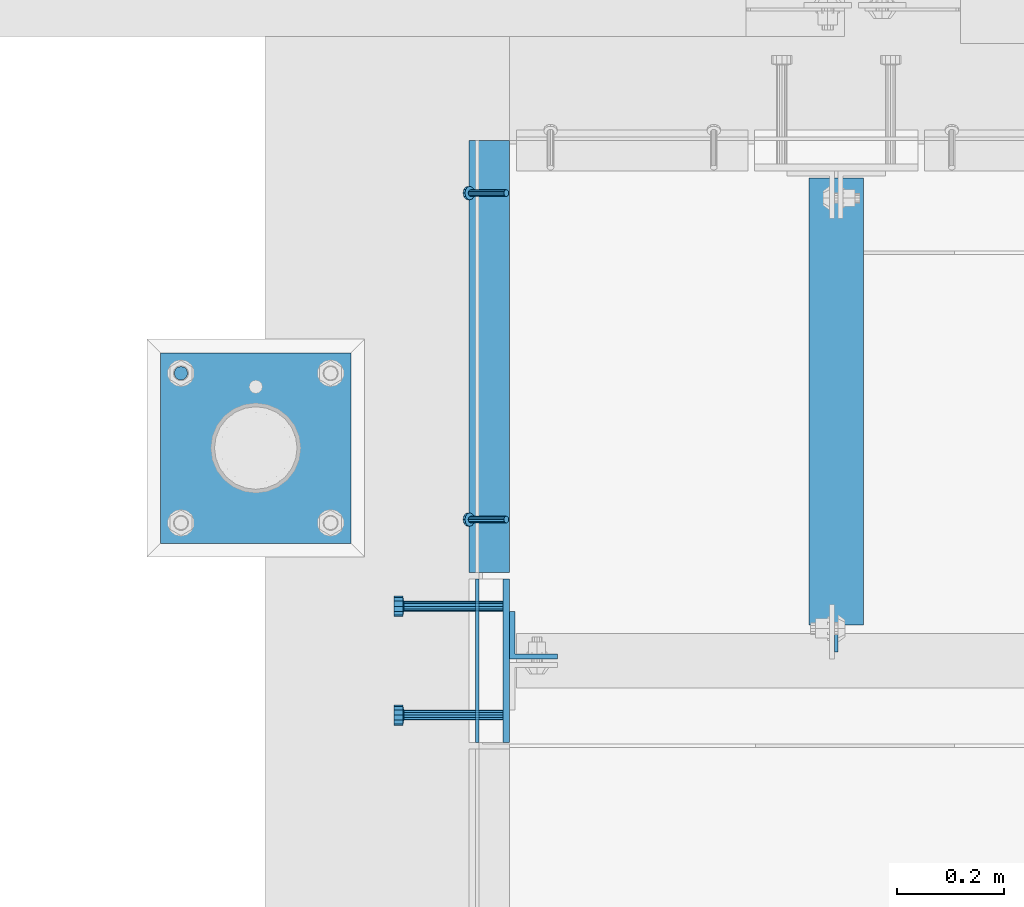
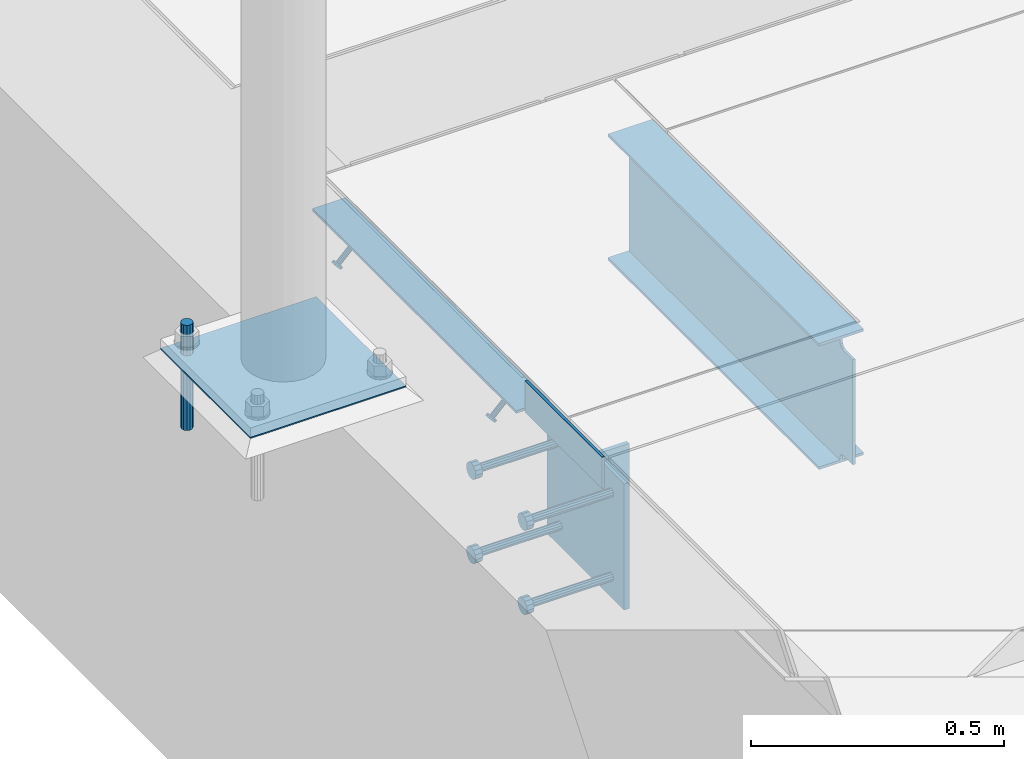
# One storey, part 2006 of 3843: 11 beams, 2 members, 5 elements without a shape of their own.
"""IFC2X3 building model written with IfcOpenShell, lengths in millimetres."""

from ifc_helpers import new_model, si_unit, frame, origin_with_axes, place, context, subcontext, project, spatial, faceted_brep, material, type_object, element, aggregate, save


model = new_model("IFC2X3")

# Units and contexts
model_context = context("Model", 3, precision=1e-05, world=origin_with_axes())
body_context = subcontext(model_context, "Body", "Model", "MODEL_VIEW")
ifc_project = project(units=[si_unit("LENGTHUNIT", "METRE", prefix="MILLI"), si_unit("AREAUNIT", "SQUARE_METRE"), si_unit("VOLUMEUNIT", "CUBIC_METRE"), si_unit("MASSUNIT", "GRAM", prefix="KILO"), si_unit("TIMEUNIT", "SECOND"), si_unit("PLANEANGLEUNIT", "RADIAN"), si_unit("SOLIDANGLEUNIT", "STERADIAN"), si_unit("THERMODYNAMICTEMPERATUREUNIT", "DEGREE_CELSIUS"), si_unit("LUMINOUSINTENSITYUNIT", "LUMEN")], contexts=[model_context])

# Site, building, storey
site_placement = place(None, origin_with_axes())
site = spatial("IfcSite", under=ifc_project, at=site_placement, CompositionType="ELEMENT")
building_placement = place(site_placement, origin_with_axes())
building = spatial("IfcBuilding", under=site, at=building_placement, Name="Undefined", CompositionType="ELEMENT")
storey_placement = place(building_placement, origin_with_axes())
storey = spatial("IfcBuildingStorey", under=building, at=storey_placement, Name="Undefined", CompositionType="ELEMENT", Elevation=0.0)

# Assembly, members
assembly_1_placement = place(storey_placement, origin_with_axes())
assembly_1 = element("IfcElementAssembly", 1, at=assembly_1_placement, inside=storey, Name="ANGLE", AssemblyPlace="NOTDEFINED", PredefinedType="RIGID_FRAME")
ifc_material_1 = material(Name="STEEL/A108")
member_type = type_object("IfcMemberType", PredefinedType="NOTDEFINED")
member_1_placement = place(assembly_1_placement, frame((41411.525, 19354.7999755859, 30397.4500030518), z_axis=(0.0, -1.0, 0.0), x_axis=(-0.707106781186548, 0.0, -0.707106781186548)))
member_1 = element("IfcMember", 2, at=member_1_placement, type_object=member_type, material=ifc_material_1, Name="HEADED STUD ANCHOR", context=body_context, shape_type="Brep", body=[
    faceted_brep([(7.27595761418343e-12, -3.18000006675175, 5.5), (0.0, -5.49999999998363, 3.1800000667572), (94.4879985803855, -5.50000000011278, 3.1800000667572), (94.4879985803782, -3.18000006687362, 5.5), (0.0, -6.3499999046162, 0.0), (94.4879985803855, -6.34999990474535, 0.0), (0.0, -5.49999999998363, -3.1800000667572), (94.4879985803855, -5.50000000011278, -3.1800000667572), (7.27595761418343e-12, -3.18000006675175, -5.5), (94.4879985803782, -3.18000006687362, -5.5), (7.27595761418343e-12, -1.81898940354586e-12, -6.34999990463257), (94.4879985803782, -1.20053300634027e-10, -6.34999990463257), (0.0, 3.18000006675175, -5.5), (94.4879985803709, 3.18000006663351, -5.5), (7.27595761418343e-12, 5.49999999998363, -3.1800000667572), (94.4879985803709, 5.49999999987267, -3.1800000667572), (7.27595761418343e-12, 6.3499999046162, 0.0), (94.4879985803673, 6.34999990450706, 0.0), (7.27595761418343e-12, 5.49999999998363, 3.1800000667572), (94.4879985803709, 5.49999999987267, 3.1800000667572), (0.0, 3.18000006675175, 5.5), (94.4879985803709, 3.18000006663351, 5.5), (7.27595761418343e-12, -1.81898940354586e-12, 6.34999990463257), (94.4879985803782, -1.20053300634027e-10, 6.34999990463257), (96.5199985498621, -10.9899997712273, 6.34999990463257), (96.5199985498548, -6.34000015270249, 10.9899997711182), (96.5199985498621, -12.6999998093743, 0.0), (96.5199985498621, -10.9899997712273, -6.34999990463257), (96.5199985498548, -6.34000015270249, -10.9899997711182), (96.5199985498475, -1.21872290037572e-10, -12.6899995803833), (96.5199985498402, 6.34000015245874, -10.9899997711182), (96.519998549833, 10.9899997709817, -6.34999990463257), (96.519998549833, 12.6999998091305, 0.0), (96.519998549833, 10.9899997709817, 6.34999990463257), (96.5199985498402, 6.34000015245874, 10.9899997711182), (96.5199985498475, -1.21872290037572e-10, 12.6899995803833), (101.599998473539, -10.9899997712328, 6.34999990463257), (101.599998473532, -6.34000015270976, 10.9899997711182), (101.599998473539, -12.6999998093797, 0.0), (101.599998473539, -10.9899997712328, -6.34999990463257), (101.599998473532, -6.34000015270976, -10.9899997711182), (101.599998473524, -1.29148247651756e-10, -12.6899995803833), (101.599998473517, 6.34000015245329, -10.9899997711182), (101.59999847351, 10.9899997709763, -6.34999990463257), (101.599998473503, 12.6999998091196, 0.0), (101.59999847351, 10.9899997709763, 6.34999990463257), (101.599998473517, 6.34000015245329, 10.9899997711182), (101.599998473524, -1.29148247651756e-10, 12.6899995803833)], [[[0, 1, 2, 3]], [[1, 4, 5, 2]], [[4, 6, 7, 5]], [[6, 8, 9, 7]], [[8, 10, 11, 9]], [[10, 12, 13, 11]], [[12, 14, 15, 13]], [[14, 16, 17, 15]], [[16, 18, 19, 17]], [[18, 20, 21, 19]], [[20, 22, 23, 21]], [[22, 0, 3, 23]], [[22, 20, 18, 16, 14, 12, 10, 8, 6, 4, 1, 0]], [[3, 2, 24, 25]], [[2, 5, 26, 24]], [[5, 7, 27, 26]], [[7, 9, 28, 27]], [[9, 11, 29, 28]], [[11, 13, 30, 29]], [[13, 15, 31, 30]], [[15, 17, 32, 31]], [[17, 19, 33, 32]], [[19, 21, 34, 33]], [[21, 23, 35, 34]], [[23, 3, 25, 35]], [[25, 24, 36, 37]], [[24, 26, 38, 36]], [[26, 27, 39, 38]], [[27, 28, 40, 39]], [[28, 29, 41, 40]], [[29, 30, 42, 41]], [[30, 31, 43, 42]], [[31, 32, 44, 43]], [[32, 33, 45, 44]], [[33, 34, 46, 45]], [[34, 35, 47, 46]], [[35, 25, 37, 47]], [[38, 39, 40, 41, 42, 43, 44, 45, 46, 47, 37, 36]]]),
])
member_2_placement = place(assembly_1_placement, frame((41411.525, 19964.3999755859, 30397.4500030518), z_axis=(0.0, -1.0, 0.0), x_axis=(-0.707106781186548, 0.0, -0.707106781186548)))
member_2 = element("IfcMember", 3, at=member_2_placement, type_object=member_type, material=ifc_material_1, Name="HEADED STUD ANCHOR", context=body_context, shape_type="Brep", body=[
    faceted_brep([(7.27595761418343e-12, -3.18000006675175, 5.5), (0.0, -5.49999999998363, 3.1800000667572), (94.4879985803855, -5.50000000011278, 3.1800000667572), (94.4879985803782, -3.18000006687362, 5.5), (0.0, -6.3499999046162, 0.0), (94.4879985803855, -6.34999990474535, 0.0), (0.0, -5.49999999998363, -3.1800000667572), (94.4879985803855, -5.50000000011278, -3.1800000667572), (7.27595761418343e-12, -3.18000006675175, -5.5), (94.4879985803782, -3.18000006687362, -5.5), (7.27595761418343e-12, -1.81898940354586e-12, -6.34999990463257), (94.4879985803782, -1.20053300634027e-10, -6.34999990463257), (0.0, 3.18000006675175, -5.5), (94.4879985803709, 3.18000006663351, -5.5), (7.27595761418343e-12, 5.49999999998363, -3.1800000667572), (94.4879985803709, 5.49999999987267, -3.1800000667572), (7.27595761418343e-12, 6.3499999046162, 0.0), (94.4879985803673, 6.34999990450706, 0.0), (7.27595761418343e-12, 5.49999999998363, 3.1800000667572), (94.4879985803709, 5.49999999987267, 3.1800000667572), (0.0, 3.18000006675175, 5.5), (94.4879985803709, 3.18000006663351, 5.5), (7.27595761418343e-12, -1.81898940354586e-12, 6.34999990463257), (94.4879985803782, -1.20053300634027e-10, 6.34999990463257), (96.5199985498621, -10.9899997712273, 6.34999990463257), (96.5199985498548, -6.34000015270249, 10.9899997711182), (96.5199985498621, -12.6999998093743, 0.0), (96.5199985498621, -10.9899997712273, -6.34999990463257), (96.5199985498548, -6.34000015270249, -10.9899997711182), (96.5199985498475, -1.21872290037572e-10, -12.6899995803833), (96.5199985498402, 6.34000015245874, -10.9899997711182), (96.519998549833, 10.9899997709817, -6.34999990463257), (96.519998549833, 12.6999998091305, 0.0), (96.519998549833, 10.9899997709817, 6.34999990463257), (96.5199985498402, 6.34000015245874, 10.9899997711182), (96.5199985498475, -1.21872290037572e-10, 12.6899995803833), (101.599998473539, -10.9899997712328, 6.34999990463257), (101.599998473532, -6.34000015270976, 10.9899997711182), (101.599998473539, -12.6999998093797, 0.0), (101.599998473539, -10.9899997712328, -6.34999990463257), (101.599998473532, -6.34000015270976, -10.9899997711182), (101.599998473524, -1.29148247651756e-10, -12.6899995803833), (101.599998473517, 6.34000015245329, -10.9899997711182), (101.59999847351, 10.9899997709763, -6.34999990463257), (101.599998473503, 12.6999998091196, 0.0), (101.59999847351, 10.9899997709763, 6.34999990463257), (101.599998473517, 6.34000015245329, 10.9899997711182), (101.599998473524, -1.29148247651756e-10, 12.6899995803833)], [[[0, 1, 2, 3]], [[1, 4, 5, 2]], [[4, 6, 7, 5]], [[6, 8, 9, 7]], [[8, 10, 11, 9]], [[10, 12, 13, 11]], [[12, 14, 15, 13]], [[14, 16, 17, 15]], [[16, 18, 19, 17]], [[18, 20, 21, 19]], [[20, 22, 23, 21]], [[22, 0, 3, 23]], [[22, 20, 18, 16, 14, 12, 10, 8, 6, 4, 1, 0]], [[3, 2, 24, 25]], [[2, 5, 26, 24]], [[5, 7, 27, 26]], [[7, 9, 28, 27]], [[9, 11, 29, 28]], [[11, 13, 30, 29]], [[13, 15, 31, 30]], [[15, 17, 32, 31]], [[17, 19, 33, 32]], [[19, 21, 34, 33]], [[21, 23, 35, 34]], [[23, 3, 25, 35]], [[25, 24, 36, 37]], [[24, 26, 38, 36]], [[26, 27, 39, 38]], [[27, 28, 40, 39]], [[28, 29, 41, 40]], [[29, 30, 42, 41]], [[30, 31, 43, 42]], [[31, 32, 44, 43]], [[32, 33, 45, 44]], [[33, 34, 46, 45]], [[34, 35, 47, 46]], [[35, 25, 37, 47]], [[38, 39, 40, 41, 42, 43, 44, 45, 46, 47, 37, 36]]]),
])

# Assembly, beams
assembly_2_placement = place(storey_placement, origin_with_axes())
assembly_2 = element("IfcElementAssembly", 4, at=assembly_2_placement, inside=storey, Name="TEMPLATE", AssemblyPlace="NOTDEFINED", PredefinedType="RIGID_FRAME")
ifc_material_2 = material(Name="STEEL/316 SS")
beam_type_1 = type_object("IfcBeamType", PredefinedType="NOTDEFINED")
beam_1_placement = place(assembly_2_placement, frame((40803.978314209, 19628.0527605797, 30581.6), z_axis=(-1.0, 0.0, 0.0), x_axis=(0.0, 0.0, -1.0)))
beam_1 = element("IfcBeam", 5, at=beam_1_placement, type_object=beam_type_1, material=ifc_material_2, Name="ANCHOR_ROD", context=body_context, shape_type="Brep", body=[
    faceted_brep([(0.0, -12.6999999999971, 0.0), (0.0, -10.9985226280696, -6.34999999999854), (253.999, -10.9985226280696, -6.34999999999854), (253.999, -12.6999999999971, 0.0), (0.0, -6.35000000000582, -10.9985226280623), (253.999, -6.35000000000582, -10.9985226280623), (0.0, 0.0, -12.6999999999971), (253.999, 0.0, -12.6999999999971), (0.0, 6.35000000000582, -10.9985226280623), (253.999, 6.35000000000582, -10.9985226280623), (0.0, 10.9985226280696, -6.34999999999854), (253.999, 10.9985226280696, -6.34999999999854), (0.0, 12.6999999999971, 0.0), (253.999, 12.6999999999971, 0.0), (0.0, 10.9985226280696, 6.34999999999854), (253.999, 10.9985226280696, 6.34999999999854), (0.0, 6.35000000000582, 10.9985226280623), (253.999, 6.35000000000582, 10.9985226280623), (0.0, 0.0, 12.6999999999971), (253.999, 0.0, 12.6999999999971), (0.0, -6.35000000000582, 10.9985226280623), (253.999, -6.35000000000582, 10.9985226280623), (0.0, -10.9985226280696, 6.34999999999854), (253.999, -10.9985226280696, 6.34999999999854)], [[[0, 1, 2, 3]], [[1, 4, 5, 2]], [[4, 6, 7, 5]], [[6, 8, 9, 7]], [[8, 10, 11, 9]], [[10, 12, 13, 11]], [[12, 14, 15, 13]], [[14, 16, 17, 15]], [[16, 18, 19, 17]], [[18, 20, 21, 19]], [[20, 22, 23, 21]], [[22, 0, 3, 23]], [[5, 7, 9, 11, 13, 15, 17, 19, 21, 23, 3, 2]], [[22, 20, 18, 16, 14, 12, 10, 8, 6, 4, 1, 0]]]),
])
ifc_material_3 = material(Name="STEEL/A36")
beam_type_2 = type_object("IfcBeamType", PredefinedType="NOTDEFINED")
beam_2_placement = place(assembly_2_placement, frame((41121.478314209, 19488.3527605797, 30506.9875), z_axis=(0.0, -1.0, 0.0), x_axis=(-1.0, 0.0, 0.0)))
beam_2 = element("IfcBeam", 6, at=beam_2_placement, type_object=beam_type_2, material=ifc_material_3, Name="TEMPLATE", context=body_context, shape_type="Brep", body=[
    faceted_brep([(0.0, 1.58750000000146, -177.800000000003), (0.0, 1.58750000000146, 177.800000000003), (355.600000000006, 1.58750000000146, 177.800000000003), (355.600000000006, 1.58750000000146, -177.800000000003), (0.0, -1.58750000000146, 177.800000000003), (355.600000000006, -1.58750000000146, 177.800000000003), (0.0, -1.58750000000146, -177.800000000003), (355.600000000006, -1.58750000000146, -177.800000000003)], [[[0, 1, 2, 3]], [[1, 4, 5, 2]], [[4, 6, 7, 5]], [[6, 0, 3, 7]], [[5, 7, 3, 2]], [[6, 4, 1, 0]]]),
])
aggregate(assembly_2, [beam_1, beam_2])

assembly_3_placement = place(storey_placement, origin_with_axes())
assembly_3 = element("IfcElementAssembly", 7, at=assembly_3_placement, inside=storey, Name="EMBED PLATE", AssemblyPlace="NOTDEFINED", PredefinedType="RIGID_FRAME")
beam_type_3 = type_object("IfcBeamType", PredefinedType="NOTDEFINED")
beam_3_placement = place(assembly_3_placement, frame((41357.5500030518, 18938.875, 30441.9), z_axis=(0.0, 0.0, 1.0), x_axis=(0.0, 1.0, 0.0)))
beam_3 = element("IfcBeam", 8, at=beam_3_placement, type_object=beam_type_3, material=ifc_material_3, Name="PLATE", context=body_context, shape_type="Brep", body=[
    faceted_brep([(0.0, 3.17500000000291, -38.0999999999985), (0.0, 3.17500000000291, 38.0999999999985), (304.800000000003, 3.17499999999927, 38.0999999999985), (304.800000000003, 3.17499999999927, -38.0999999999985), (0.0, -3.17500000000291, 38.0999999999985), (304.800000000003, -3.17499999999927, 38.0999999999985), (0.0, -3.17500000000291, -38.0999999999985), (304.800000000003, -3.17499999999927, -38.0999999999985)], [[[0, 1, 2, 3]], [[1, 4, 5, 2]], [[4, 6, 7, 5]], [[6, 0, 3, 7]], [[5, 7, 3, 2]], [[6, 4, 1, 0]]]),
])
beam_type_4 = type_object("IfcBeamType", PredefinedType="NOTDEFINED")
beam_4_placement = place(assembly_3_placement, frame((41411.5250030518, 19091.275, 30397.45), z_axis=(0.0, 1.0, 0.0), x_axis=(0.0, 0.0, -1.0)))
beam_4 = element("IfcBeam", 9, at=beam_4_placement, type_object=beam_type_4, material=ifc_material_3, Name="EMBED PLATE", context=body_context, shape_type="Brep", body=[
    faceted_brep([(-1.0550138540566e-10, 6.34999999999854, -152.400000000664), (1.0550138540566e-10, 6.34999999999854, 152.400000000656), (304.799999999999, 6.34999999999854, 152.400000000001), (304.799999999999, 6.34999999999854, -152.400000000001), (1.0550138540566e-10, -6.34999999999854, 152.400000000656), (304.799999999999, -6.34999999999854, 152.400000000001), (-1.0550138540566e-10, -6.34999999999854, -152.400000000664), (304.799999999999, -6.34999999999854, -152.400000000001)], [[[0, 1, 2, 3]], [[1, 4, 5, 2]], [[4, 6, 7, 5]], [[6, 0, 3, 7]], [[5, 7, 3, 2]], [[6, 4, 1, 0]]]),
])

# Beam
beam_type_5 = type_object("IfcBeamType", Name="L3X3X1/4", PredefinedType="NOTDEFINED")
beam_5_placement = place(assembly_1_placement, frame((41379.775, 19256.3749999856, 30365.7000030518), z_axis=(0.0, 0.0, -1.0), x_axis=(0.0, 1.0, 0.0)))
beam_5 = element("IfcBeam", 10, at=beam_5_placement, type_object=beam_type_5, material=ifc_material_3, Name="ANGLE", ObjectType="L3X3X1/4", context=body_context, shape_type="Brep", body=[
    faceted_brep([(0.0, 38.0999999999985, -38.0999999999985), (0.0, 38.0999999999985, 38.0999999999985), (806.450021508055, 38.0999999999985, 38.0999999999985), (806.450021508055, 38.0999999999985, -38.0999999999985), (0.0, 31.75, 38.0999999999985), (806.450021508055, 31.75, 38.0999999999985), (0.0, 31.75, -31.75), (806.450021508055, 31.75, -31.75), (0.0, -38.0999999999985, -31.75), (806.450021508055, -38.0999999999985, -31.75), (0.0, -38.0999999999985, -38.0999999999985), (806.450021508055, -38.0999999999985, -38.0999999999985)], [[[0, 1, 2, 3]], [[1, 4, 5, 2]], [[4, 6, 7, 5]], [[6, 8, 9, 7]], [[8, 10, 11, 9]], [[10, 0, 3, 11]], [[5, 7, 9, 11, 3, 2]], [[10, 8, 6, 4, 1, 0]]]),
])

aggregate(assembly_1, [member_1, member_2, beam_5])

# Assembly, beam
assembly_4_placement = place(storey_placement, origin_with_axes())
assembly_4 = element("IfcElementAssembly", 11, at=assembly_4_placement, inside=storey, Name="BEAM", AssemblyPlace="NOTDEFINED", PredefinedType="RIGID_FRAME")
beam_type_6 = type_object("IfcBeamType", Name="L3-1/2X3-1/2X3/8", PredefinedType="NOTDEFINED")
beam_6_placement = place(assembly_4_placement, frame((41462.3250030518, 19138.9, 30365.7), z_axis=(0.0, 1.0, 0.0), x_axis=(0.0, 0.0, -1.0)))
beam_6 = element("IfcBeam", 12, at=beam_6_placement, type_object=beam_type_6, material=ifc_material_3, Name="ANGLE", ObjectType="L3-1/2X3-1/2X3/8", context=body_context, shape_type="Brep", body=[
    faceted_brep([(-3.63797880709171e-12, 44.4499999999971, -44.4500000000007), (-3.63797880709171e-12, 44.4499999999971, 44.4500000000007), (228.600000000006, 44.4499999999971, 44.4500000000007), (228.600000000006, 44.4499999999971, -44.4500000000007), (0.0, 34.9250000000029, 44.4500000000007), (228.600000000006, 34.9250000000029, 44.4500000000007), (0.0, 34.9250000000029, -34.9250000000029), (228.600000000006, 34.9250000000029, -34.9249999999993), (0.0, -44.4499999999971, -34.9249999999993), (228.600000000006, -44.4499999999971, -34.9249999999993), (3.63797880709171e-12, -44.4499999999971, -44.4500000000007), (228.600000000006, -44.4499999999971, -44.4500000000007)], [[[0, 1, 2, 3]], [[1, 4, 5, 2]], [[4, 6, 7, 5]], [[6, 8, 9, 7]], [[8, 10, 11, 9]], [[10, 0, 3, 11]], [[5, 7, 9, 11, 3, 2]], [[10, 8, 6, 4, 1, 0]]]),
])
aggregate(assembly_4, [beam_6])

# Beam
beam_type_7 = type_object("IfcBeamType", PredefinedType="NOTDEFINED")
beam_7_placement = place(assembly_3_placement, frame((41405.1750030518, 18989.675, 30346.65), z_axis=(0.0, -1.0, 0.0), x_axis=(-1.0, 0.0, 0.0)))
beam_7 = element("IfcBeam", 13, at=beam_7_placement, type_object=beam_type_7, material=ifc_material_1, Name="HEADED STUD ANCHOR", context=body_context, shape_type="Brep", body=[
    faceted_brep([(0.0, -9.52000045776367, 0.0), (0.0, -8.25, -4.76000022888184), (184.912000000004, -8.25, -4.76000022888184), (184.912000000004, -9.52000045776367, 0.0), (0.0, -4.76000022888184, -8.25), (184.912000000004, -4.76000022888184, -8.25), (0.0, 0.0, -9.52000045776367), (184.912000000004, 0.0, -9.52000045776367), (0.0, 4.76000022888184, -8.25), (184.912000000004, 4.76000022888184, -8.25), (0.0, 8.25, -4.76000022888184), (184.912000000004, 8.25, -4.76000022888184), (0.0, 9.52000045776367, 0.0), (184.912000000004, 9.52000045776367, 0.0), (0.0, 8.25, 4.76000022888184), (184.912000000004, 8.25, 4.76000022888184), (0.0, 4.76000022888184, 8.25), (184.912000000004, 4.76000022888184, 8.25), (0.0, 0.0, 9.52000045776367), (184.912000000004, 0.0, 9.52000045776367), (0.0, -4.76000022888184, 8.25), (184.912000000004, -4.76000022888184, 8.25), (0.0, -8.25, 4.76000022888184), (184.912000000004, -8.25, 4.76000022888184), (186.944000000003, -16.5, -9.52000045776367), (186.944000000003, -19.0499992370605, 0.0), (186.944000000003, -9.52000045776367, -16.5), (186.944000000003, 0.0, -19.0499992370605), (186.944000000003, 9.52000045776367, -16.5), (186.944000000003, 16.5, -9.52000045776367), (186.944000000003, 19.0499992370605, 0.0), (186.944000000003, 16.5, 9.52000045776367), (186.944000000003, 9.52000045776367, 16.5), (186.944000000003, 0.0, 19.0499992370605), (186.944000000003, -9.52000045776367, 16.5), (186.944000000003, -16.5, 9.52000045776367), (203.199999999997, -16.5, -9.52000045776367), (203.199999999997, -19.0499992370605, 0.0), (203.199999999997, -9.52000045776367, -16.5), (203.199999999997, 0.0, -19.0499992370605), (203.199999999997, 9.52000045776367, -16.5), (203.199999999997, 16.5, -9.52000045776367), (203.199999999997, 19.0499992370605, 0.0), (203.199999999997, 16.5, 9.52000045776367), (203.199999999997, 9.52000045776367, 16.5), (203.199999999997, 0.0, 19.0499992370605), (203.199999999997, -9.52000045776367, 16.5), (203.199999999997, -16.5, 9.52000045776367)], [[[0, 1, 2, 3]], [[1, 4, 5, 2]], [[4, 6, 7, 5]], [[6, 8, 9, 7]], [[8, 10, 11, 9]], [[10, 12, 13, 11]], [[12, 14, 15, 13]], [[14, 16, 17, 15]], [[16, 18, 19, 17]], [[18, 20, 21, 19]], [[20, 22, 23, 21]], [[22, 0, 3, 23]], [[22, 20, 18, 16, 14, 12, 10, 8, 6, 4, 1, 0]], [[3, 2, 24, 25]], [[2, 5, 26, 24]], [[5, 7, 27, 26]], [[7, 9, 28, 27]], [[9, 11, 29, 28]], [[11, 13, 30, 29]], [[13, 15, 31, 30]], [[15, 17, 32, 31]], [[17, 19, 33, 32]], [[19, 21, 34, 33]], [[21, 23, 35, 34]], [[23, 3, 25, 35]], [[25, 24, 36, 37]], [[24, 26, 38, 36]], [[26, 27, 39, 38]], [[27, 28, 40, 39]], [[28, 29, 41, 40]], [[29, 30, 42, 41]], [[30, 31, 43, 42]], [[31, 32, 44, 43]], [[32, 33, 45, 44]], [[33, 34, 46, 45]], [[34, 35, 47, 46]], [[35, 25, 37, 47]], [[38, 39, 40, 41, 42, 43, 44, 45, 46, 47, 37, 36]]]),
])

beam_8_placement = place(assembly_3_placement, frame((41405.1750030518, 18989.675, 30143.45), z_axis=(0.0, -1.0, 0.0), x_axis=(-1.0, 0.0, 0.0)))
beam_8 = element("IfcBeam", 14, at=beam_8_placement, type_object=beam_type_7, material=ifc_material_1, Name="HEADED STUD ANCHOR", context=body_context, shape_type="Brep", body=[
    faceted_brep([(0.0, -9.52000045776367, 0.0), (0.0, -8.25, -4.76000022888184), (184.912000000004, -8.25, -4.76000022888184), (184.912000000004, -9.52000045776367, 0.0), (0.0, -4.76000022888184, -8.25), (184.912000000004, -4.76000022888184, -8.25), (0.0, 0.0, -9.52000045776367), (184.912000000004, 0.0, -9.52000045776367), (0.0, 4.76000022888184, -8.25), (184.912000000004, 4.76000022888184, -8.25), (0.0, 8.25, -4.76000022888184), (184.912000000004, 8.25, -4.76000022888184), (0.0, 9.52000045776367, 0.0), (184.912000000004, 9.52000045776367, 0.0), (0.0, 8.25, 4.76000022888184), (184.912000000004, 8.25, 4.76000022888184), (0.0, 4.76000022888184, 8.25), (184.912000000004, 4.76000022888184, 8.25), (0.0, 0.0, 9.52000045776367), (184.912000000004, 0.0, 9.52000045776367), (0.0, -4.76000022888184, 8.25), (184.912000000004, -4.76000022888184, 8.25), (0.0, -8.25, 4.76000022888184), (184.912000000004, -8.25, 4.76000022888184), (186.944000000003, -16.5, -9.52000045776367), (186.944000000003, -19.0499992370605, 0.0), (186.944000000003, -9.52000045776367, -16.5), (186.944000000003, 0.0, -19.0499992370605), (186.944000000003, 9.52000045776367, -16.5), (186.944000000003, 16.5, -9.52000045776367), (186.944000000003, 19.0499992370605, 0.0), (186.944000000003, 16.5, 9.52000045776367), (186.944000000003, 9.52000045776367, 16.5), (186.944000000003, 0.0, 19.0499992370605), (186.944000000003, -9.52000045776367, 16.5), (186.944000000003, -16.5, 9.52000045776367), (203.199999999997, -16.5, -9.52000045776367), (203.199999999997, -19.0499992370605, 0.0), (203.199999999997, -9.52000045776367, -16.5), (203.199999999997, 0.0, -19.0499992370605), (203.199999999997, 9.52000045776367, -16.5), (203.199999999997, 16.5, -9.52000045776367), (203.199999999997, 19.0499992370605, 0.0), (203.199999999997, 16.5, 9.52000045776367), (203.199999999997, 9.52000045776367, 16.5), (203.199999999997, 0.0, 19.0499992370605), (203.199999999997, -9.52000045776367, 16.5), (203.199999999997, -16.5, 9.52000045776367)], [[[0, 1, 2, 3]], [[1, 4, 5, 2]], [[4, 6, 7, 5]], [[6, 8, 9, 7]], [[8, 10, 11, 9]], [[10, 12, 13, 11]], [[12, 14, 15, 13]], [[14, 16, 17, 15]], [[16, 18, 19, 17]], [[18, 20, 21, 19]], [[20, 22, 23, 21]], [[22, 0, 3, 23]], [[22, 20, 18, 16, 14, 12, 10, 8, 6, 4, 1, 0]], [[3, 2, 24, 25]], [[2, 5, 26, 24]], [[5, 7, 27, 26]], [[7, 9, 28, 27]], [[9, 11, 29, 28]], [[11, 13, 30, 29]], [[13, 15, 31, 30]], [[15, 17, 32, 31]], [[17, 19, 33, 32]], [[19, 21, 34, 33]], [[21, 23, 35, 34]], [[23, 3, 25, 35]], [[25, 24, 36, 37]], [[24, 26, 38, 36]], [[26, 27, 39, 38]], [[27, 28, 40, 39]], [[28, 29, 41, 40]], [[29, 30, 42, 41]], [[30, 31, 43, 42]], [[31, 32, 44, 43]], [[32, 33, 45, 44]], [[33, 34, 46, 45]], [[34, 35, 47, 46]], [[35, 25, 37, 47]], [[38, 39, 40, 41, 42, 43, 44, 45, 46, 47, 37, 36]]]),
])

beam_9_placement = place(assembly_3_placement, frame((41405.1750030518, 19192.875, 30346.65), z_axis=(0.0, -1.0, 0.0), x_axis=(-1.0, 0.0, 0.0)))
beam_9 = element("IfcBeam", 15, at=beam_9_placement, type_object=beam_type_7, material=ifc_material_3, Name="PLATE", context=body_context, shape_type="Brep", body=[
    faceted_brep([(0.0, -9.52000045776367, 0.0), (0.0, -8.25, -4.76000022888184), (184.912000000004, -8.25, -4.76000022888184), (184.912000000004, -9.52000045776367, 0.0), (0.0, -4.76000022888184, -8.25), (184.912000000004, -4.76000022888184, -8.25), (0.0, 0.0, -9.52000045776367), (184.912000000004, 0.0, -9.52000045776367), (0.0, 4.76000022888184, -8.25), (184.912000000004, 4.76000022888184, -8.25), (0.0, 8.25, -4.76000022888184), (184.912000000004, 8.25, -4.76000022888184), (0.0, 9.52000045776367, 0.0), (184.912000000004, 9.52000045776367, 0.0), (0.0, 8.25, 4.76000022888184), (184.912000000004, 8.25, 4.76000022888184), (0.0, 4.76000022888184, 8.25), (184.912000000004, 4.76000022888184, 8.25), (0.0, 0.0, 9.52000045776367), (184.912000000004, 0.0, 9.52000045776367), (0.0, -4.76000022888184, 8.25), (184.912000000004, -4.76000022888184, 8.25), (0.0, -8.25, 4.76000022888184), (184.912000000004, -8.25, 4.76000022888184), (186.944000000003, -16.5, -9.52000045776367), (186.944000000003, -19.0499992370605, 0.0), (186.944000000003, -9.52000045776367, -16.5), (186.944000000003, 0.0, -19.0499992370605), (186.944000000003, 9.52000045776367, -16.5), (186.944000000003, 16.5, -9.52000045776367), (186.944000000003, 19.0499992370605, 0.0), (186.944000000003, 16.5, 9.52000045776367), (186.944000000003, 9.52000045776367, 16.5), (186.944000000003, 0.0, 19.0499992370605), (186.944000000003, -9.52000045776367, 16.5), (186.944000000003, -16.5, 9.52000045776367), (203.199999999997, -16.5, -9.52000045776367), (203.199999999997, -19.0499992370605, 0.0), (203.199999999997, -9.52000045776367, -16.5), (203.199999999997, 0.0, -19.0499992370605), (203.199999999997, 9.52000045776367, -16.5), (203.199999999997, 16.5, -9.52000045776367), (203.199999999997, 19.0499992370605, 0.0), (203.199999999997, 16.5, 9.52000045776367), (203.199999999997, 9.52000045776367, 16.5), (203.199999999997, 0.0, 19.0499992370605), (203.199999999997, -9.52000045776367, 16.5), (203.199999999997, -16.5, 9.52000045776367)], [[[0, 1, 2, 3]], [[1, 4, 5, 2]], [[4, 6, 7, 5]], [[6, 8, 9, 7]], [[8, 10, 11, 9]], [[10, 12, 13, 11]], [[12, 14, 15, 13]], [[14, 16, 17, 15]], [[16, 18, 19, 17]], [[18, 20, 21, 19]], [[20, 22, 23, 21]], [[22, 0, 3, 23]], [[22, 20, 18, 16, 14, 12, 10, 8, 6, 4, 1, 0]], [[3, 2, 24, 25]], [[2, 5, 26, 24]], [[5, 7, 27, 26]], [[7, 9, 28, 27]], [[9, 11, 29, 28]], [[11, 13, 30, 29]], [[13, 15, 31, 30]], [[15, 17, 32, 31]], [[17, 19, 33, 32]], [[19, 21, 34, 33]], [[21, 23, 35, 34]], [[23, 3, 25, 35]], [[25, 24, 36, 37]], [[24, 26, 38, 36]], [[26, 27, 39, 38]], [[27, 28, 40, 39]], [[28, 29, 41, 40]], [[29, 30, 42, 41]], [[30, 31, 43, 42]], [[31, 32, 44, 43]], [[32, 33, 45, 44]], [[33, 34, 46, 45]], [[34, 35, 47, 46]], [[35, 25, 37, 47]], [[38, 39, 40, 41, 42, 43, 44, 45, 46, 47, 37, 36]]]),
])

beam_10_placement = place(assembly_3_placement, frame((41405.1750030518, 19192.875, 30143.45), z_axis=(0.0, -1.0, 0.0), x_axis=(-1.0, 0.0, 0.0)))
beam_10 = element("IfcBeam", 16, at=beam_10_placement, type_object=beam_type_7, material=ifc_material_1, Name="HEADED STUD ANCHOR", context=body_context, shape_type="Brep", body=[
    faceted_brep([(0.0, -9.52000045776367, 0.0), (0.0, -8.25, -4.76000022888184), (184.912000000004, -8.25, -4.76000022888184), (184.912000000004, -9.52000045776367, 0.0), (0.0, -4.76000022888184, -8.25), (184.912000000004, -4.76000022888184, -8.25), (0.0, 0.0, -9.52000045776367), (184.912000000004, 0.0, -9.52000045776367), (0.0, 4.76000022888184, -8.25), (184.912000000004, 4.76000022888184, -8.25), (0.0, 8.25, -4.76000022888184), (184.912000000004, 8.25, -4.76000022888184), (0.0, 9.52000045776367, 0.0), (184.912000000004, 9.52000045776367, 0.0), (0.0, 8.25, 4.76000022888184), (184.912000000004, 8.25, 4.76000022888184), (0.0, 4.76000022888184, 8.25), (184.912000000004, 4.76000022888184, 8.25), (0.0, 0.0, 9.52000045776367), (184.912000000004, 0.0, 9.52000045776367), (0.0, -4.76000022888184, 8.25), (184.912000000004, -4.76000022888184, 8.25), (0.0, -8.25, 4.76000022888184), (184.912000000004, -8.25, 4.76000022888184), (186.944000000003, -16.5, -9.52000045776367), (186.944000000003, -19.0499992370605, 0.0), (186.944000000003, -9.52000045776367, -16.5), (186.944000000003, 0.0, -19.0499992370605), (186.944000000003, 9.52000045776367, -16.5), (186.944000000003, 16.5, -9.52000045776367), (186.944000000003, 19.0499992370605, 0.0), (186.944000000003, 16.5, 9.52000045776367), (186.944000000003, 9.52000045776367, 16.5), (186.944000000003, 0.0, 19.0499992370605), (186.944000000003, -9.52000045776367, 16.5), (186.944000000003, -16.5, 9.52000045776367), (203.199999999997, -16.5, -9.52000045776367), (203.199999999997, -19.0499992370605, 0.0), (203.199999999997, -9.52000045776367, -16.5), (203.199999999997, 0.0, -19.0499992370605), (203.199999999997, 9.52000045776367, -16.5), (203.199999999997, 16.5, -9.52000045776367), (203.199999999997, 19.0499992370605, 0.0), (203.199999999997, 16.5, 9.52000045776367), (203.199999999997, 9.52000045776367, 16.5), (203.199999999997, 0.0, 19.0499992370605), (203.199999999997, -9.52000045776367, 16.5), (203.199999999997, -16.5, 9.52000045776367)], [[[0, 1, 2, 3]], [[1, 4, 5, 2]], [[4, 6, 7, 5]], [[6, 8, 9, 7]], [[8, 10, 11, 9]], [[10, 12, 13, 11]], [[12, 14, 15, 13]], [[14, 16, 17, 15]], [[16, 18, 19, 17]], [[18, 20, 21, 19]], [[20, 22, 23, 21]], [[22, 0, 3, 23]], [[22, 20, 18, 16, 14, 12, 10, 8, 6, 4, 1, 0]], [[3, 2, 24, 25]], [[2, 5, 26, 24]], [[5, 7, 27, 26]], [[7, 9, 28, 27]], [[9, 11, 29, 28]], [[11, 13, 30, 29]], [[13, 15, 31, 30]], [[15, 17, 32, 31]], [[17, 19, 33, 32]], [[19, 21, 34, 33]], [[21, 23, 35, 34]], [[23, 3, 25, 35]], [[25, 24, 36, 37]], [[24, 26, 38, 36]], [[26, 27, 39, 38]], [[27, 28, 40, 39]], [[28, 29, 41, 40]], [[29, 30, 42, 41]], [[30, 31, 43, 42]], [[31, 32, 44, 43]], [[32, 33, 45, 44]], [[33, 34, 46, 45]], [[34, 35, 47, 46]], [[35, 25, 37, 47]], [[38, 39, 40, 41, 42, 43, 44, 45, 46, 47, 37, 36]]]),
])

aggregate(assembly_3, [beam_3, beam_7, beam_8, beam_9, beam_10, beam_4])

# Assembly, beam
assembly_5_placement = place(storey_placement, origin_with_axes())
assembly_5 = element("IfcElementAssembly", 17, at=assembly_5_placement, inside=storey, Name="BEAM", AssemblyPlace="NOTDEFINED", PredefinedType="RIGID_FRAME")
ifc_material_4 = material(Name="STEEL/A992")
beam_type_8 = type_object("IfcBeamType", Name="W12X16", PredefinedType="NOTDEFINED")
beam_11_placement = place(assembly_5_placement, frame((42027.475, 19091.275, 30251.4), z_axis=(0.0, 0.0, 1.0), x_axis=(0.0, 1.0, 0.0)))
beam_11 = element("IfcBeam", 18, at=beam_11_placement, type_object=beam_type_8, material=ifc_material_4, Name="BEAM", ObjectType="W12X16", context=body_context, shape_type="Brep", body=[
    faceted_brep([(15.875, -3.17500000000291, -127.0), (15.875, 3.17500000000291, -127.0), (53.9750001907341, 3.17500000000291, -127.0), (53.9750001907341, -3.17500000000291, -127.0), (58.8350797087805, 3.17500000000291, -127.966729922588), (58.8350797087805, -3.17500000000291, -127.966729922588), (62.9552561769342, 3.17500000000291, -130.719743823065), (62.9552561769342, -3.17500000000291, -130.719743823065), (65.7082700774117, 3.17500000000291, -134.839920291219), (65.7082700774117, -3.17500000000291, -134.839920291219), (66.6749999999993, -3.17500000000291, -139.699999809265), (66.6749999999993, 3.17500000000291, -139.699999809265), (66.6749999999993, 3.17500000000291, -146.049999999999), (66.6749999999993, 50.8000000000029, -146.049999999999), (66.6749999999993, 50.8000000000029, -152.400000000001), (66.6749999999993, -50.8000000000029, -152.400000000001), (66.6749999999993, -50.8000000000029, -146.049999999999), (66.6749999999993, -3.17500000000291, -146.049999999999), (901.699996948231, -50.8000000000029, 146.049999999999), (901.699996948231, -50.8000000000029, 152.400000000001), (66.6749999999993, -50.8000000000029, 152.400000000001), (66.6749999999993, -50.8000000000029, 146.049999999999), (901.699996948231, 50.8000000000029, 152.400000000001), (66.6749999999993, 50.8000000000029, 152.400000000001), (901.699996948231, 50.8000000000029, 146.049999999999), (66.6749999999993, 50.8000000000029, 146.049999999999), (901.699996948231, 3.17500000000291, 146.049999999999), (66.6749999999993, 3.17500000000291, 146.049999999999), (53.9750001907341, -3.17500000000291, 127.0), (53.9750001907341, 3.17500000000291, 127.0), (15.875, 3.17500000000291, 127.0), (15.875, -3.17500000000291, 127.0), (58.8350797087805, -3.17500000000291, 127.966729922588), (58.8350797087805, 3.17500000000291, 127.966729922588), (62.9552561769342, -3.17500000000291, 130.719743823065), (62.9552561769342, 3.17500000000291, 130.719743823065), (65.7082700774117, -3.17500000000291, 134.839920291219), (65.7082700774117, 3.17500000000291, 134.839920291219), (66.6749999999993, -3.17500000000291, 139.699999809265), (66.6749999999993, 3.17500000000291, 139.699999809265), (66.6749999999993, -3.17500000000291, 146.049999999999), (901.699996948231, -3.17500000000291, 146.049999999999), (901.699996948231, 3.17500000000291, -146.049999999999), (901.699996948231, -3.17500000000291, -146.049999999999), (901.699996948231, -50.8000000000029, -146.049999999999), (901.699996948231, -50.8000000000029, -152.400000000001), (901.699996948231, 50.8000000000029, -152.400000000001), (901.699996948231, 50.8000000000029, -146.049999999999), (15.875, 3.17500000000291, -116.299999999999), (15.875, 3.17500000000291, 114.299999999999)], [[[0, 1, 2, 3]], [[3, 2, 4, 5]], [[5, 4, 6, 7]], [[7, 6, 8, 9]], [[10, 11, 12, 13, 14, 15, 16, 17]], [[9, 8, 11, 10]], [[18, 19, 20, 21]], [[19, 22, 23, 20]], [[22, 24, 25, 23]], [[24, 26, 27, 25]], [[28, 29, 30, 31]], [[32, 33, 29, 28]], [[34, 35, 33, 32]], [[36, 37, 35, 34]], [[38, 39, 37, 36]], [[20, 23, 25, 27, 39, 38, 40, 21]], [[41, 18, 21, 40]], [[42, 26, 24, 22, 19, 18, 41, 43, 44, 45, 46, 47]], [[44, 43, 17, 16]], [[45, 44, 16, 15]], [[46, 45, 15, 14]], [[47, 46, 14, 13]], [[42, 47, 13, 12]], [[6, 4, 2, 1, 48, 49, 30, 29, 33, 35, 37, 39, 27, 26, 42, 12, 11, 8]], [[31, 30, 49, 48, 1, 0]], [[43, 41, 40, 38, 36, 34, 32, 28, 31, 0, 3, 5, 7, 9, 10, 17]]]),
])
aggregate(assembly_5, [beam_11])

save(model, "model.ifc")
